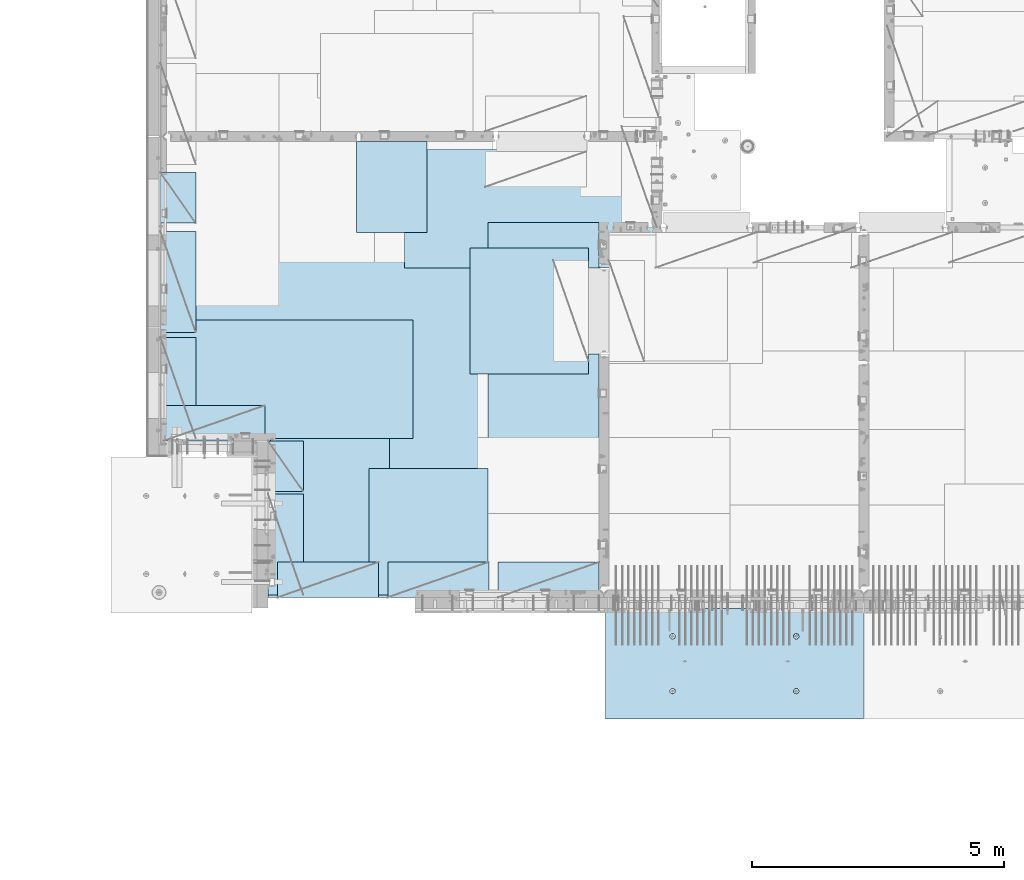
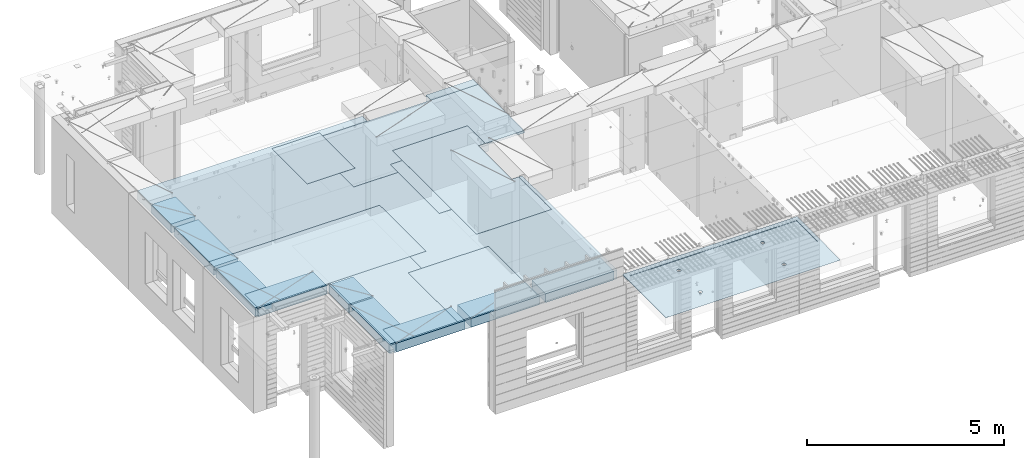
# One storey, part 172 of 309: 16 plates, 2 slabs, 16 elements without a shape of their own.
"""IFC2X3 building model written with IfcOpenShell, lengths in millimetres."""

from ifc_helpers import new_model, si_unit, frame, origin_with_axes, place, context, subcontext, project, spatial, faceted_brep, material, type_object, element, aggregate, save


model = new_model("IFC2X3")

# Units and contexts
model_context = context("Model", 3, precision=1e-05, world=origin_with_axes())
body_context = subcontext(model_context, "Body", "Model", "MODEL_VIEW")
ifc_project = project(units=[si_unit("LENGTHUNIT", "METRE", prefix="MILLI"), si_unit("AREAUNIT", "SQUARE_METRE"), si_unit("VOLUMEUNIT", "CUBIC_METRE"), si_unit("MASSUNIT", "GRAM", prefix="KILO"), si_unit("TIMEUNIT", "SECOND"), si_unit("PLANEANGLEUNIT", "RADIAN"), si_unit("SOLIDANGLEUNIT", "STERADIAN"), si_unit("THERMODYNAMICTEMPERATUREUNIT", "DEGREE_CELSIUS"), si_unit("LUMINOUSINTENSITYUNIT", "LUMEN")], contexts=[model_context])

# Site, building, storey
site_placement = place(None, origin_with_axes())
site = spatial("IfcSite", under=ifc_project, at=site_placement, CompositionType="ELEMENT")
building_placement = place(site_placement, origin_with_axes())
building = spatial("IfcBuilding", under=site, at=building_placement, CompositionType="ELEMENT")
storey_placement = place(building_placement, origin_with_axes())
storey = spatial("IfcBuildingStorey", under=building, at=storey_placement, Name="7", CompositionType="ELEMENT", Elevation=0.0)

# Assembly, slab
assembly_1_placement = place(storey_placement, origin_with_axes())
assembly_1 = element("IfcElementAssembly", 1, at=assembly_1_placement, inside=storey, AssemblyPlace="NOTDEFINED", PredefinedType="REINFORCEMENT_UNIT")
ifc_material_1 = material(Name="CONCRETE/C35/45")
slab_type_1 = type_object("IfcSlabType", PredefinedType="NOTDEFINED")
slab_1_placement = place(assembly_1_placement, frame((21799.9998568133, 7629.99655735226, 102715.0), z_axis=(-1.11800000013248e-06, -0.999999999999375, 0.0), x_axis=(-0.999999999999093, 1.34699999998405e-06, 0.0)))
slab_1 = element("IfcSlab", 2, at=slab_1_placement, type_object=slab_type_1, material=ifc_material_1, PredefinedType="FLOOR", context=body_context, shape_type="Brep", body=[
    faceted_brep([(1280.18660296697, -0.909710330801317, 566.185914834692), (1281.90603936524, 15.0, 565.627238643067), (1289.08870074667, 15.0, 579.724052269637), (1287.6392435987, -0.766307145458995, 580.77714154713), (1300.27597263497, 15.0, 590.911354296481), (1299.23047672458, -0.652565147232963, 592.350351889299), (1314.37276691139, 15.0, 598.0940536547), (1313.8256792785, -0.579567785971449, 599.777808538672), (1329.99919113403, 15.0, 600.569057686296), (1329.99918875315, -0.55441981376498, 602.336605392405), (1345.62562202428, 15.0, 598.094095752294), (1346.17270510536, -0.57956733671017, 599.77785206156), (1359.72243565085, 15.0, 590.911434370867), (1360.76792762748, -0.652564292380703, 592.350434701655), (1370.9097376777, 15.0, 579.724162482574), (1372.35919188042, -0.766305968267261, 580.77725558627), (1378.09243703591, 15.0, 565.627368206145), (1379.81187177946, -0.909708946070168, 566.186048981303), (1380.56744106751, 15.0, 550.000943983501), (1382.39343843141, -1.06877680234902, 550.00094644312), (1378.09247913351, 15.0, 534.374513093253), (1379.84630966614, -1.22795456201129, 533.804661621162), (1370.90981775208, 15.0, 520.277699466684), (1372.41492595986, -1.37164529091388, 519.184177442045), (1359.72254586379, 15.0, 509.09039743984), (1360.82369295531, -1.485742713543, 507.574802784429), (1345.62575158736, 15.0, 501.907698081623), (1346.20723365079, -1.55902761995094, 500.118088510166), (1329.99932736472, 15.0, 499.432694050024), (1329.99932990324, -1.5842854254297, 497.548116160773), (1314.37289647447, 15.0, 501.907655984027), (1313.7914192164, -1.55902807114762, 500.118044797301), (1300.2760828479, 15.0, 509.090317365454), (1299.17493978209, -1.48574357148027, 507.574719664685), (1289.08878082105, 15.0, 520.277589253747), (1287.58367545073, -1.37164647120517, 519.184063095515), (1281.90608146284, 15.0, 534.374383530176), (1280.15225231554, -1.22795594864874, 533.804527284575), (1279.43107743124, 15.0, 550.000807752819), (1277.60507990177, -1.06877825934498, 550.000805293201), (5009.99979799347, -4.99999995394319, 149.999864183354), (99.9997979937543, -4.99999013317574, 150.001528673352), (99.9997979764994, -13.6269858322921, 150.001528664759), (5009.99979797622, -13.6270008655847, 149.99986417476), (100.000487896599, 15.0, 2184.99365234375), (100.000487876598, 5.00000921862375, 2184.99365234375), (5110.00048828125, 15.0, 2184.99365234375), (5010.00048789632, 15.0, 2184.99365234375), (5010.00048787632, 4.99999939870031, 2184.99365234375), (5110.00048828125, 4.99999919869879, 2184.99365234375), (5110.0, 15.0, -1.47338141687214e-10), (5110.0, -15.0, -1.47338141687214e-10), (0.0, 15.0, 0.0), (2.51020537689328e-10, -14.9999911366176, 0.00113955305187119), (0.000232657715969253, 15.0, 2184.99365234375), (0.000232657715969253, 5.00000941862527, 2184.99365234375), (3730.22251860999, 9.43573209954775, 1618.83113331269), (3730.82387439738, 15.0, 1619.026526548), (3728.29325229765, 15.0, 1635.00410637115), (3727.6790114725, 9.59468073869357, 1635.00410554377), (3737.64324823311, 9.2922483417351, 1604.23170736994), (3738.16798272994, 15.0, 1604.61295037772), (3749.2178332121, 9.17831542248314, 1592.63906930656), (3749.60668480233, 15.0, 1593.17427912115), (3763.813280134, 9.10513637620898, 1585.19312428745), (3764.02028075758, 15.0, 1585.83020961879), (3779.99786830435, 9.07991536622285, 1582.62689367248), (3779.99786739818, 15.0, 1583.29963056268), (3796.18244954539, 9.10513682675082, 1585.19316793742), (3795.97544722132, 15.0, 1585.8302526624), (3810.77787636647, 9.17831627919804, 1592.6391523067), (3810.38902339161, 15.0, 1593.17436099496), (3822.35243006372, 9.29224952030927, 1604.23182155193), (3821.82769464817, 15.0, 1604.61306306735), (3829.77312031467, 9.43573348419159, 1618.83126745597), (3829.17176415053, 15.0, 1619.02665902261), (3832.31658386647, 9.59468219359405, 1635.00424649058), (3831.70234320665, 15.0, 1635.0042456632), (3829.73873198269, 9.75352115777787, 1651.16605933226), (3829.17172110693, 15.0, 1650.98182548635), (3822.29677618333, 9.8967177845916, 1665.73626979138), (3821.82761277437, 15.0, 1665.39540165663), (3810.72219128265, 10.0102957908966, 1677.29279557827), (3810.38891070198, 15.0, 1676.8340729132), (3796.14797068512, 10.0831877069577, 1684.70952519025), (3795.97531474672, 15.0, 1684.17814241556), (3779.99772735736, 10.1082990436407, 1687.26459658035), (3779.99772810613, 15.0, 1686.70872147167), (3763.84749089728, 10.0831872583221, 1684.70948172999), (3764.02014828298, 15.0, 1684.17809937195), (3749.27329023921, 10.0102949372667, 1677.29271288508), (3749.6065721127, 15.0, 1676.83399103939), (3737.6987364208, 9.89671660910244, 1665.73615591634), (3738.16790085613, 15.0, 1665.395288967), (3730.25681983225, 9.75351977504033, 1651.16592537868), (3730.82383135377, 15.0, 1650.98169301174), (1280.22251492937, 9.43569802264392, 1618.82783196606), (1280.8238743996, 15.0, 1619.023226398), (1278.29325229988, 15.0, 1635.00080622115), (1277.67900760369, 9.59464667354769, 1635.00080539377), (1287.64324510154, 9.29221425422293, 1604.2284049431), (1288.16798273216, 15.0, 1604.60965022772), (1299.21783093693, 9.17828132653085, 1592.63576602199), (1299.60668480455, 15.0, 1593.17097897115), (1313.81327893874, 9.10510227482882, 1585.18982045196), (1314.02028075981, 15.0, 1585.82690946879), (1329.99786830658, 9.07988126298005, 1582.62358964711), (1329.9978674004, 15.0, 1583.29633041268), (1346.18245074511, 9.10510272538522, 1585.18986410193), (1345.97544722355, 15.0, 1585.8269525124), (1360.77787864609, 9.1782821832312, 1592.63584902213), (1360.38902339383, 15.0, 1593.17106084496), (1372.35243319974, 9.29221543279709, 1604.2285191251), (1371.8276946504, 15.0, 1604.60976291735), (1379.77312399974, 9.43569940728776, 1618.82796610935), (1379.17176415276, 15.0, 1619.02335887261), (1382.31658773973, 9.59464812844817, 1635.00094634059), (1381.70234320888, 15.0, 1635.0009455132), (1379.73873566521, 9.75348710437538, 1651.16276037807), (1379.17172110915, 15.0, 1650.97852533635), (1372.29677931523, 9.89668374179746, 1665.73297191523), (1371.82761277659, 15.0, 1665.39210150663), (1360.72219355815, 10.0102617564989, 1677.28949855719), (1360.3889107042, 15.0, 1676.8307727632), (1346.14797188228, 10.0831536779588, 1684.70622871793), (1345.97531474894, 15.0, 1684.17484226556), (1329.99772735958, 10.1082650164899, 1687.26130029707), (1329.99772810835, 15.0, 1686.70542132167), (1313.84748970455, 10.0831532293232, 1684.70618525766), (1314.0201482852, 15.0, 1684.17479922195), (1299.27328796815, 10.010260902869, 1677.28941586399), (1299.60657211492, 15.0, 1676.83069088939), (1287.69873329334, 9.89668256629375, 1665.73285804018), (1288.16790085835, 15.0, 1665.391988817), (1280.25681615416, 9.7534857216524, 1651.16262642448), (1280.82383135599, 15.0, 1650.97839286174), (3809.72243564863, 15.0, 590.914734520867), (3810.76792535197, -0.652530257968465, 592.353731722741), (3796.17270390819, -0.579533307682141, 599.781148533887), (3795.62562202206, 15.0, 598.097395902295), (3820.90973767548, 15.0, 579.727462632573), (3822.35918874851, -0.76627192547312, 580.780553462419), (3828.09243703369, 15.0, 565.630668356144), (3829.81186809693, -0.909674892682233, 566.189347935494), (3830.56744106529, 15.0, 550.004244133502), (3832.39343455815, -1.06874273720314, 550.004246593115), (3828.09247913129, 15.0, 534.377813243253), (3829.84630598107, -1.22792048507836, 533.807962967788), (3820.90981774986, 15.0, 520.280999616684), (3822.41492282383, -1.3716112034017, 519.187479868876), (3809.72254586156, 15.0, 509.093697589839), (3810.82369067569, -1.48570861757617, 507.578106068997), (3795.62575158514, 15.0, 501.910998231622), (3796.20723245107, -1.55899351858534, 500.121392345655), (3779.99932736249, 15.0, 499.435994200024), (3779.99932990101, -1.58425132217235, 497.551420186142), (3764.37289647224, 15.0, 501.910956134026), (3763.79142041166, -1.55899396976747, 500.121348632794), (3750.27608284568, 15.0, 509.093617515454), (3749.17494205726, -1.48570947552798, 507.578022949257), (3739.08878081883, 15.0, 520.280889403746), (3737.58367858229, -1.37161238366389, 519.187365522354), (3731.90608146061, 15.0, 534.377683680175), (3730.15225599616, -1.22792187171581, 533.807828631209), (3737.63924672617, -0.766273102650302, 580.780439423285), (3749.23047899565, -0.652531112835277, 592.353648910393), (3763.82568047123, -0.579533756972523, 599.781105011002), (3779.99918875093, -0.5543857866287, 602.339901675684), (3727.60508377059, -1.0687441941991, 550.004105443206), (3730.18660664506, -0.90967627739883, 566.189213788893), (3779.99919113181, 15.0, 600.572357836296), (3764.37276690917, 15.0, 598.097353804698), (3750.27597263274, 15.0, 590.914654446481), (3739.08870074445, 15.0, 579.727352419636), (3731.90603936302, 15.0, 565.630538793067), (3729.43107742902, 15.0, 550.00410790282)], [[[0, 1, 2, 3]], [[3, 2, 4, 5]], [[5, 4, 6, 7]], [[7, 6, 8, 9]], [[10, 11, 9, 8]], [[12, 13, 11, 10]], [[14, 15, 13, 12]], [[16, 17, 15, 14]], [[18, 19, 17, 16]], [[20, 21, 19, 18]], [[22, 23, 21, 20]], [[24, 25, 23, 22]], [[26, 27, 25, 24]], [[27, 26, 28, 29]], [[29, 28, 30, 31]], [[31, 30, 32, 33]], [[33, 32, 34, 35]], [[35, 34, 36, 37]], [[37, 36, 38, 39]], [[39, 38, 1, 0]], [[40, 41, 42, 43]], [[41, 44, 45, 42]], [[46, 47, 48, 49]], [[50, 46, 49, 51]], [[52, 50, 51, 53]], [[54, 52, 53, 55]], [[44, 54, 55, 45]], [[53, 51, 49, 48, 43, 42, 45, 55]], [[47, 40, 43, 48]], [[56, 57, 58, 59]], [[60, 61, 57, 56]], [[62, 63, 61, 60]], [[64, 65, 63, 62]], [[66, 67, 65, 64]], [[68, 69, 67, 66]], [[70, 71, 69, 68]], [[71, 70, 72, 73]], [[73, 72, 74, 75]], [[75, 74, 76, 77]], [[77, 76, 78, 79]], [[79, 78, 80, 81]], [[81, 80, 82, 83]], [[83, 82, 84, 85]], [[85, 84, 86, 87]], [[87, 86, 88, 89]], [[90, 91, 89, 88]], [[92, 93, 91, 90]], [[94, 95, 93, 92]], [[59, 58, 95, 94]], [[96, 97, 98, 99]], [[100, 101, 97, 96]], [[102, 103, 101, 100]], [[104, 105, 103, 102]], [[106, 107, 105, 104]], [[108, 109, 107, 106]], [[110, 111, 109, 108]], [[111, 110, 112, 113]], [[113, 112, 114, 115]], [[115, 114, 116, 117]], [[117, 116, 118, 119]], [[119, 118, 120, 121]], [[121, 120, 122, 123]], [[123, 122, 124, 125]], [[125, 124, 126, 127]], [[127, 126, 128, 129]], [[130, 131, 129, 128]], [[132, 133, 131, 130]], [[134, 135, 133, 132]], [[99, 98, 135, 134]], [[136, 137, 138, 139]], [[140, 141, 137, 136]], [[142, 143, 141, 140]], [[144, 145, 143, 142]], [[146, 147, 145, 144]], [[148, 149, 147, 146]], [[150, 151, 149, 148]], [[152, 153, 151, 150]], [[153, 152, 154, 155]], [[155, 154, 156, 157]], [[157, 156, 158, 159]], [[159, 158, 160, 161]], [[161, 160, 162, 163]], [[44, 41, 40, 47], [3, 5, 7, 9, 11, 13, 15, 17, 19, 21, 23, 25, 27, 29, 31, 33, 35, 37, 39, 0], [164, 165, 166, 167, 138, 137, 141, 143, 145, 147, 149, 151, 153, 155, 157, 159, 161, 163, 168, 169], [132, 130, 128, 126, 124, 122, 120, 118, 116, 114, 112, 110, 108, 106, 104, 102, 100, 96, 99, 134], [92, 90, 88, 86, 84, 82, 80, 78, 76, 74, 72, 70, 68, 66, 64, 62, 60, 56, 59, 94]], [[139, 138, 167, 170]], [[166, 171, 170, 167]], [[165, 172, 171, 166]], [[164, 173, 172, 165]], [[169, 174, 173, 164]], [[168, 175, 174, 169]], [[163, 162, 175, 168]], [[46, 50, 52, 54, 44, 47], [34, 32, 30, 28, 26, 24, 22, 20, 18, 16, 14, 12, 10, 8, 6, 4, 2, 1, 38, 36], [160, 158, 156, 154, 152, 150, 148, 146, 144, 142, 140, 136, 139, 170, 171, 172, 173, 174, 175, 162], [101, 103, 105, 107, 109, 111, 113, 115, 117, 119, 121, 123, 125, 127, 129, 131, 133, 135, 98, 97], [61, 63, 65, 67, 69, 71, 73, 75, 77, 79, 81, 83, 85, 87, 89, 91, 93, 95, 58, 57]]]),
])
aggregate(assembly_1, [slab_1])

# Assembly, plate
assembly_2_placement = place(storey_placement, origin_with_axes())
assembly_2 = element("IfcElementAssembly", 3, at=assembly_2_placement, inside=storey, Name="Steel Assembly", AssemblyPlace="NOTDEFINED", PredefinedType="NOTDEFINED")
ifc_material_2 = material()
plate_type_1 = type_object("IfcPlateType", PredefinedType="NOTDEFINED")
plate_1_placement = place(assembly_2_placement, frame((14009.7695320312, 12275.0000289158, 102695.1), z_axis=(0.0, 1.0, 0.0), x_axis=(1.0, 0.0, 0.0)))
plate_1 = element("IfcPlate", 4, at=plate_1_placement, type_object=plate_type_1, material=ifc_material_2, Name="1/2", context=body_context, shape_type="Brep", body=[
    faceted_brep([(0.0, -35.0, 0.0), (0.0, -35.0, 2500.0), (0.0, 35.0, 2500.0), (0.0, 35.0, 0.0), (2349.99951171875, -35.0, 2500.0), (2349.99951171875, 35.0, 2500.0), (2350.0, -35.0, 0.0), (2350.0, 35.0, 0.0)], [[[0, 1, 2, 3]], [[1, 4, 5, 2]], [[4, 6, 7, 5]], [[6, 0, 3, 7]], [[5, 7, 3, 2]], [[6, 4, 1, 0]]]),
])
aggregate(assembly_2, [plate_1])

assembly_3_placement = place(storey_placement, origin_with_axes())
assembly_3 = element("IfcElementAssembly", 5, at=assembly_3_placement, inside=storey, Name="Steel Assembly", AssemblyPlace="NOTDEFINED", PredefinedType="NOTDEFINED")
plate_2_placement = place(assembly_3_placement, frame((14360.0, 10400.0, 102695.1), z_axis=(0.0, -1.0, 0.0), x_axis=(-1.0, 3.00000001838171e-08, 0.0)))
plate_2 = element("IfcPlate", 6, at=plate_2_placement, type_object=plate_type_1, material=ifc_material_2, Name="1/2", context=body_context, shape_type="Brep", body=[
    faceted_brep([(0.0, -35.0, 0.0), (0.0, -35.0, 2500.0), (0.0, 35.0, 2500.0), (0.0, 35.0, 0.0), (2349.99951171875, -35.0, 2500.0), (2349.99951171875, 35.0, 2500.0), (2350.0, -35.0, 0.0), (2350.0, 35.0, 0.0)], [[[0, 1, 2, 3]], [[1, 4, 5, 2]], [[4, 6, 7, 5]], [[6, 0, 3, 7]], [[5, 7, 3, 2]], [[6, 4, 1, 0]]]),
])
aggregate(assembly_3, [plate_2])

assembly_4_placement = place(storey_placement, origin_with_axes())
assembly_4 = element("IfcElementAssembly", 7, at=assembly_4_placement, inside=storey, Name="Steel Assembly", AssemblyPlace="NOTDEFINED", PredefinedType="NOTDEFINED")
plate_3_placement = place(assembly_4_placement, frame((12710.0, 16725.0, 102695.1), z_axis=(1.0, 0.0, 0.0), x_axis=(0.0, -1.0, 0.0)))
plate_3 = element("IfcPlate", 8, at=plate_3_placement, type_object=plate_type_1, material=ifc_material_2, context=body_context, shape_type="Brep", body=[
    faceted_brep([(0.0, -35.0, 0.0), (0.0, -35.0, 5000.0), (0.0, 35.0, 5000.0), (0.0, 35.0, 0.0), (2349.99951171875, -35.0, 5000.0), (2349.99951171875, 35.0, 5000.0), (2350.0, -35.0, 0.0), (2350.0, 35.0, 0.0)], [[[0, 1, 2, 3]], [[1, 4, 5, 2]], [[4, 6, 7, 5]], [[6, 0, 3, 7]], [[5, 7, 3, 2]], [[6, 4, 1, 0]]]),
])
aggregate(assembly_4, [plate_3])

assembly_5_placement = place(storey_placement, origin_with_axes())
assembly_5 = element("IfcElementAssembly", 9, at=assembly_5_placement, inside=storey, Name="Steel Assembly", AssemblyPlace="NOTDEFINED", PredefinedType="NOTDEFINED")
plate_4_placement = place(assembly_5_placement, frame((10060.0, 7900.0, 102695.1), z_axis=(0.0, 1.0, 0.0), x_axis=(1.0, 0.0, 0.0)))
plate_4 = element("IfcPlate", 10, at=plate_4_placement, type_object=plate_type_1, material=ifc_material_2, context=body_context, shape_type="Brep", body=[
    faceted_brep([(0.0, -35.0, 0.0), (0.0, -35.0, 5000.0), (0.0, 35.0, 5000.0), (0.0, 35.0, 0.0), (2349.99951171875, -35.0, 5000.0), (2349.99951171875, 35.0, 5000.0), (2350.0, -35.0, 0.0), (2350.0, 35.0, 0.0)], [[[0, 1, 2, 3]], [[1, 4, 5, 2]], [[4, 6, 7, 5]], [[6, 0, 3, 7]], [[5, 7, 3, 2]], [[6, 4, 1, 0]]]),
])
aggregate(assembly_5, [plate_4])

assembly_6_placement = place(storey_placement, origin_with_axes())
assembly_6 = element("IfcElementAssembly", 11, at=assembly_6_placement, inside=storey, Name="Steel Assembly", AssemblyPlace="NOTDEFINED", PredefinedType="NOTDEFINED")
plate_5_placement = place(assembly_6_placement, frame((12880.0, 11000.0, 102695.1), z_axis=(-1.0, 3.00000001838171e-08, 0.0), x_axis=(0.0, 1.0, 0.0)))
plate_5 = element("IfcPlate", 12, at=plate_5_placement, type_object=plate_type_1, material=ifc_material_2, context=body_context, shape_type="Brep", body=[
    faceted_brep([(0.0, -35.0, 0.0), (0.0, -35.0, 5000.0), (0.0, 35.0, 5000.0), (0.0, 35.0, 0.0), (2349.99951171875, -35.0, 5000.0), (2349.99951171875, 35.0, 5000.0), (2350.0, -35.0, 0.0), (2350.0, 35.0, 0.0)], [[[0, 1, 2, 3]], [[1, 4, 5, 2]], [[4, 6, 7, 5]], [[6, 0, 3, 7]], [[5, 7, 3, 2]], [[6, 4, 1, 0]]]),
])
aggregate(assembly_6, [plate_5])

assembly_7_placement = place(storey_placement, origin_with_axes())
assembly_7 = element("IfcElementAssembly", 13, at=assembly_7_placement, inside=storey, Name="Steel Assembly", AssemblyPlace="NOTDEFINED", PredefinedType="NOTDEFINED")
plate_type_2 = type_object("IfcPlateType", PredefinedType="NOTDEFINED")
plate_6_placement = place(assembly_7_placement, frame((7879.99987792969, 13000.0, 102595.3), z_axis=(1.0, 0.0, 0.0), x_axis=(0.0, -1.0, 0.0)))
plate_6 = element("IfcPlate", 14, at=plate_6_placement, type_object=plate_type_2, material=ifc_material_2, Name="RE1", context=body_context, shape_type="Brep", body=[
    faceted_brep([(1.81898940354586e-12, -135.0, 1.81898940354586e-12), (0.0, -135.0, 699.999999999996), (0.0, 135.0, 699.999999999996), (1.81898940354586e-12, 135.0, 1.81898940354586e-12), (1999.99951171875, -135.0, 699.999999999993), (1999.99951171875, 135.0, 699.999999999993), (2000.0, -135.0, -3.63797880709171e-12), (2000.0, 135.0, -3.63797880709171e-12)], [[[0, 1, 2, 3]], [[1, 4, 5, 2]], [[4, 6, 7, 5]], [[6, 0, 3, 7]], [[5, 7, 3, 2]], [[6, 4, 1, 0]]]),
])
aggregate(assembly_7, [plate_6])

assembly_8_placement = place(storey_placement, origin_with_axes())
assembly_8 = element("IfcElementAssembly", 15, at=assembly_8_placement, inside=storey, Name="Steel Assembly", AssemblyPlace="NOTDEFINED", PredefinedType="NOTDEFINED")
plate_7_placement = place(assembly_8_placement, frame((7945.00085423865, 10950.0001036336, 102595.3), z_axis=(0.0, 1.0, 0.0), x_axis=(1.0, 0.0, 0.0)))
plate_7 = element("IfcPlate", 16, at=plate_7_placement, type_object=plate_type_2, material=ifc_material_2, Name="RE1", context=body_context, shape_type="Brep", body=[
    faceted_brep([(1.81898940354586e-12, -135.0, 1.81898940354586e-12), (0.0, -135.0, 699.999999999996), (0.0, 135.0, 699.999999999996), (1.81898940354586e-12, 135.0, 1.81898940354586e-12), (1999.99951171875, -135.0, 699.999999999993), (1999.99951171875, 135.0, 699.999999999993), (2000.0, -135.0, -3.63797880709171e-12), (2000.0, 135.0, -3.63797880709171e-12)], [[[0, 1, 2, 3]], [[1, 4, 5, 2]], [[4, 6, 7, 5]], [[6, 0, 3, 7]], [[5, 7, 3, 2]], [[6, 4, 1, 0]]]),
])
aggregate(assembly_8, [plate_7])

assembly_9_placement = place(storey_placement, origin_with_axes())
assembly_9 = element("IfcElementAssembly", 17, at=assembly_9_placement, inside=storey, Name="Steel Assembly", AssemblyPlace="NOTDEFINED", PredefinedType="NOTDEFINED")
plate_8_placement = place(assembly_9_placement, frame((10009.9998779297, 9900.0, 102595.3), z_axis=(1.0, 0.0, 0.0), x_axis=(0.0, -1.0, 0.0)))
plate_8 = element("IfcPlate", 18, at=plate_8_placement, type_object=plate_type_2, material=ifc_material_2, Name="RE1", context=body_context, shape_type="Brep", body=[
    faceted_brep([(1.81898940354586e-12, -135.0, 1.81898940354586e-12), (0.0, -135.0, 699.999999999996), (0.0, 135.0, 699.999999999996), (1.81898940354586e-12, 135.0, 1.81898940354586e-12), (1999.99951171875, -135.0, 699.999999999993), (1999.99951171875, 135.0, 699.999999999993), (2000.0, -135.0, -3.63797880709171e-12), (2000.0, 135.0, -3.63797880709171e-12)], [[[0, 1, 2, 3]], [[1, 4, 5, 2]], [[4, 6, 7, 5]], [[6, 0, 3, 7]], [[5, 7, 3, 2]], [[6, 4, 1, 0]]]),
])
aggregate(assembly_9, [plate_8])

assembly_10_placement = place(storey_placement, origin_with_axes())
assembly_10 = element("IfcElementAssembly", 19, at=assembly_10_placement, inside=storey, Name="Steel Assembly", AssemblyPlace="NOTDEFINED", PredefinedType="NOTDEFINED")
plate_9_placement = place(assembly_10_placement, frame((10009.9999999293, 10950.0, 102595.3), z_axis=(1.0, 0.0, 0.0), x_axis=(0.0, -1.0, 0.0)))
plate_9 = element("IfcPlate", 20, at=plate_9_placement, type_object=plate_type_2, material=ifc_material_2, Name="RE1_1/2", context=body_context, shape_type="Brep", body=[
    faceted_brep([(1.81898940354586e-12, -135.0, 1.81898940354586e-12), (0.0, -135.0, 699.999999999996), (0.0, 135.0, 699.999999999996), (1.81898940354586e-12, 135.0, 1.81898940354586e-12), (999.99951171875, -135.0, 700.0), (999.99951171875, 135.0, 700.0), (1000.0, -135.0, 0.0), (1000.0, 135.0, 0.0)], [[[0, 1, 2, 3]], [[1, 4, 5, 2]], [[4, 6, 7, 5]], [[6, 0, 3, 7]], [[5, 7, 3, 2]], [[6, 4, 1, 0]]]),
])
aggregate(assembly_10, [plate_9])

assembly_11_placement = place(storey_placement, origin_with_axes())
assembly_11 = element("IfcElementAssembly", 21, at=assembly_11_placement, inside=storey, Name="Steel Assembly", AssemblyPlace="NOTDEFINED", PredefinedType="NOTDEFINED")
plate_10_placement = place(assembly_11_placement, frame((7879.99999992931, 16265.0, 102595.3), z_axis=(1.0, 0.0, 0.0), x_axis=(0.0, -1.0, 0.0)))
plate_10 = element("IfcPlate", 22, at=plate_10_placement, type_object=plate_type_2, material=ifc_material_2, Name="RE1_1/2", context=body_context, shape_type="Brep", body=[
    faceted_brep([(1.81898940354586e-12, -135.0, 1.81898940354586e-12), (0.0, -135.0, 699.999999999996), (0.0, 135.0, 699.999999999996), (1.81898940354586e-12, 135.0, 1.81898940354586e-12), (999.99951171875, -135.0, 700.0), (999.99951171875, 135.0, 700.0), (1000.0, -135.0, 0.0), (1000.0, 135.0, 0.0)], [[[0, 1, 2, 3]], [[1, 4, 5, 2]], [[4, 6, 7, 5]], [[6, 0, 3, 7]], [[5, 7, 3, 2]], [[6, 4, 1, 0]]]),
])
aggregate(assembly_11, [plate_10])

assembly_12_placement = place(storey_placement, origin_with_axes())
assembly_12 = element("IfcElementAssembly", 23, at=assembly_12_placement, inside=storey, Name="Steel Assembly", AssemblyPlace="NOTDEFINED", PredefinedType="NOTDEFINED")
plate_11_placement = place(assembly_12_placement, frame((10200.0008542386, 7850.00010363356, 102595.3), z_axis=(0.0, 1.0, 0.0), x_axis=(1.0, 0.0, 0.0)))
plate_11 = element("IfcPlate", 24, at=plate_11_placement, type_object=plate_type_2, material=ifc_material_2, Name="RE1", context=body_context, shape_type="Brep", body=[
    faceted_brep([(1.81898940354586e-12, -135.0, 1.81898940354586e-12), (0.0, -135.0, 699.999999999996), (0.0, 135.0, 699.999999999996), (1.81898940354586e-12, 135.0, 1.81898940354586e-12), (1999.99951171875, -135.0, 699.999999999993), (1999.99951171875, 135.0, 699.999999999993), (2000.0, -135.0, -3.63797880709171e-12), (2000.0, 135.0, -3.63797880709171e-12)], [[[0, 1, 2, 3]], [[1, 4, 5, 2]], [[4, 6, 7, 5]], [[6, 0, 3, 7]], [[5, 7, 3, 2]], [[6, 4, 1, 0]]]),
])
aggregate(assembly_12, [plate_11])

assembly_13_placement = place(storey_placement, origin_with_axes())
assembly_13 = element("IfcElementAssembly", 25, at=assembly_13_placement, inside=storey, Name="Steel Assembly", AssemblyPlace="NOTDEFINED", PredefinedType="NOTDEFINED")
plate_12_placement = place(assembly_13_placement, frame((14565.0008542386, 7850.00010363356, 102595.3), z_axis=(0.0, 1.0, 0.0), x_axis=(1.0, 0.0, 0.0)))
plate_12 = element("IfcPlate", 26, at=plate_12_placement, type_object=plate_type_2, material=ifc_material_2, Name="RE1", context=body_context, shape_type="Brep", body=[
    faceted_brep([(1.81898940354586e-12, -135.0, 1.81898940354586e-12), (0.0, -135.0, 699.999999999996), (0.0, 135.0, 699.999999999996), (1.81898940354586e-12, 135.0, 1.81898940354586e-12), (1999.99951171875, -135.0, 699.999999999993), (1999.99951171875, 135.0, 699.999999999993), (2000.0, -135.0, -3.63797880709171e-12), (2000.0, 135.0, -3.63797880709171e-12)], [[[0, 1, 2, 3]], [[1, 4, 5, 2]], [[4, 6, 7, 5]], [[6, 0, 3, 7]], [[5, 7, 3, 2]], [[6, 4, 1, 0]]]),
])
aggregate(assembly_13, [plate_12])

assembly_14_placement = place(storey_placement, origin_with_axes())
assembly_14 = element("IfcElementAssembly", 27, at=assembly_14_placement, inside=storey, Name="Steel Assembly", AssemblyPlace="NOTDEFINED", PredefinedType="NOTDEFINED")
plate_13_placement = place(assembly_14_placement, frame((12382.5008542386, 7850.00010363356, 102595.3), z_axis=(0.0, 1.0, 0.0), x_axis=(1.0, 0.0, 0.0)))
plate_13 = element("IfcPlate", 28, at=plate_13_placement, type_object=plate_type_2, material=ifc_material_2, Name="RE1", context=body_context, shape_type="Brep", body=[
    faceted_brep([(1.81898940354586e-12, -135.0, 1.81898940354586e-12), (0.0, -135.0, 699.999999999996), (0.0, 135.0, 699.999999999996), (1.81898940354586e-12, 135.0, 1.81898940354586e-12), (1999.99951171875, -135.0, 699.999999999993), (1999.99951171875, 135.0, 699.999999999993), (2000.0, -135.0, -3.63797880709171e-12), (2000.0, 135.0, -3.63797880709171e-12)], [[[0, 1, 2, 3]], [[1, 4, 5, 2]], [[4, 6, 7, 5]], [[6, 0, 3, 7]], [[5, 7, 3, 2]], [[6, 4, 1, 0]]]),
])
aggregate(assembly_14, [plate_13])

assembly_15_placement = place(storey_placement, origin_with_axes())
assembly_15 = element("IfcElementAssembly", 29, at=assembly_15_placement, inside=storey, Name="Steel Assembly", AssemblyPlace="NOTDEFINED", PredefinedType="NOTDEFINED")
plate_14_placement = place(assembly_15_placement, frame((7879.99987792969, 15100.0, 102595.3), z_axis=(1.0, 0.0, 0.0), x_axis=(0.0, -1.0, 0.0)))
plate_14 = element("IfcPlate", 30, at=plate_14_placement, type_object=plate_type_2, material=ifc_material_2, Name="RE1", context=body_context, shape_type="Brep", body=[
    faceted_brep([(1.81898940354586e-12, -135.0, 1.81898940354586e-12), (0.0, -135.0, 699.999999999996), (0.0, 135.0, 699.999999999996), (1.81898940354586e-12, 135.0, 1.81898940354586e-12), (1999.99951171875, -135.0, 699.999999999993), (1999.99951171875, 135.0, 699.999999999993), (2000.0, -135.0, -3.63797880709171e-12), (2000.0, 135.0, -3.63797880709171e-12)], [[[0, 1, 2, 3]], [[1, 4, 5, 2]], [[4, 6, 7, 5]], [[6, 0, 3, 7]], [[5, 7, 3, 2]], [[6, 4, 1, 0]]]),
])
aggregate(assembly_15, [plate_14])

# Assembly, plates, slab
assembly_16_placement = place(storey_placement, origin_with_axes())
assembly_16 = element("IfcElementAssembly", 31, at=assembly_16_placement, inside=storey, AssemblyPlace="NOTDEFINED", PredefinedType="REINFORCEMENT_UNIT")
plate_type_3 = type_object("IfcPlateType", PredefinedType="NOTDEFINED")
plate_15_placement = place(assembly_16_placement, frame((13159.9998642727, 15079.9997757405, 102725.45), z_axis=(-1.0, 3.00000001838171e-08, 0.0), x_axis=(0.0, 1.0, 0.0)))
plate_15 = element("IfcPlate", 32, at=plate_15_placement, type_object=plate_type_3, material=ifc_material_2, context=body_context, shape_type="Brep", body=[
    faceted_brep([(0.0, -5.0, 0.0), (0.0, -5.0, 1399.99963378906), (0.0, 5.0, 1399.99963378906), (0.0, 5.0, 0.0), (1800.00024414063, -5.0, 1399.99963378906), (1800.00024414063, 5.0, 1399.99963378906), (1800.00024414063, -5.0, 0.0), (1800.00024414063, 5.0, 0.0)], [[[0, 1, 2, 3]], [[1, 4, 5, 2]], [[4, 6, 7, 5]], [[6, 0, 3, 7]], [[5, 7, 3, 2]], [[6, 4, 1, 0]]]),
])
plate_type_4 = type_object("IfcPlateType", PredefinedType="NOTDEFINED")
plate_16_placement = place(assembly_16_placement, frame((16559.9994828029, 15279.9995850056, 102725.45), z_axis=(0.0, -1.0, 0.0), x_axis=(-1.0, 3.00000001838171e-08, 0.0)))
plate_16 = element("IfcPlate", 33, at=plate_16_placement, type_object=plate_type_4, material=ifc_material_2, context=body_context, shape_type="Brep", body=[
    faceted_brep([(0.0, -5.0, 2604.99950854713), (0.0, 5.0, 2604.99950854713), (200.234115600586, 5.0, 2604.99950854713), (200.234115600586, -5.0, 2604.99950854713), (200.234115600586, 5.0, 904.999508547127), (200.234115600586, -5.0, 904.999508547127), (0.0, -5.0, 904.999508547127), (0.0, 5.0, 904.999508547127), (0.0, -5.0, 4271.99951171875), (2191.99951171875, -5.0, 4271.99951171875), (2191.99951171875, 5.0, 4271.99951171875), (0.0, 5.0, 4271.99951171875), (2191.99951171875, -5.0, 0.0), (2191.99951171875, 5.0, 0.0), (0.0, -5.0, 0.0), (0.0, 5.0, 0.0)], [[[0, 1, 2, 3]], [[3, 2, 4, 5]], [[6, 5, 4, 7]], [[8, 9, 10, 11]], [[9, 12, 13, 10]], [[12, 14, 15, 13]], [[15, 14, 6, 7]], [[2, 1, 11, 10, 13, 15, 7, 4]], [[8, 11, 1, 0]], [[14, 12, 9, 8, 0, 3, 5, 6]]]),
])
ifc_material_3 = material(Name="CONCRETE/C30/37")
slab_type_2 = type_object("IfcSlabType", PredefinedType="NOTDEFINED")
slab_2_placement = place(assembly_16_placement, frame((10010.0, 7850.0, 102595.0), z_axis=(0.0, 1.0, 0.0), x_axis=(1.0, 0.0, 0.0)))
slab_2 = element("IfcSlab", 34, at=slab_2_placement, type_object=slab_type_2, material=ifc_material_3, PredefinedType="FLOOR", context=body_context, shape_type="Brep", body=[
    faceted_brep([(4453.68914550781, -135.0, 9130.0), (-2130.0, -135.0, 9130.0), (-2130.0, -135.0, 3100.0), (0.0, -135.0, 3100.0), (1.81898940354586e-12, -135.0, 1.81898940354586e-12), (6650.0, -135.0, 0.0), (6650.0, -135.0, 4825.00007645847), (6349.76536720235, -135.0, 4825.00007645847), (6349.76536720235, -135.0, 6525.00007645847), (6649.99998634297, -135.0, 6525.00007645847), (6650.0, -135.0, 7330.0), (7700.0, -135.0, 7330.0), (7700.0, -135.0, 9130.0), (6319.99914550781, -135.0, 9130.0), (6319.99914550781, -135.0, 8830.0), (6153.68914550781, -135.0, 8830.0), (4520.0, -135.0, 8830.0), (4453.69, -135.0, 8830.0), (-2130.0, 135.0, 9130.0), (4453.68914550781, 135.0, 9130.0), (-2130.0, 135.0, 3100.0), (0.0, 135.0, 3100.0), (1.81898940354586e-12, 135.0, 1.81898940354586e-12), (6650.0, 135.0, 0.0), (6650.0, 135.0, 4825.00007645847), (6349.76536720235, 135.0, 4825.00007645847), (6349.76536720235, 135.0, 6525.00007645847), (6650.0, 135.0, 6525.00007645847), (6650.0, 135.0, 7330.0), (7700.0, 135.0, 7330.0), (7700.0, 135.0, 9130.0), (6319.99914550781, 135.0, 9130.0), (6319.99914550781, 135.0, 8830.0), (6153.68914550781, 135.0, 8830.0), (4520.0, 135.0, 8830.0), (4453.69, 135.0, 8830.0)], [[[0, 1, 2, 3, 4, 5, 6, 7, 8, 9, 10, 11, 12, 13, 14, 15, 16, 17]], [[18, 1, 0, 19]], [[2, 1, 18, 20]], [[3, 2, 20, 21]], [[4, 3, 21, 22]], [[5, 4, 22, 23]], [[5, 23, 24, 6]], [[6, 24, 25, 7]], [[7, 25, 26, 8]], [[9, 8, 26, 27]], [[28, 10, 9, 27]], [[11, 10, 28, 29]], [[12, 11, 29, 30]], [[12, 30, 31, 13]], [[13, 31, 32, 14]], [[15, 14, 32, 33, 34, 16]], [[16, 34, 35, 17]], [[33, 32, 31, 30, 29, 28, 27, 26, 25, 24, 23, 22, 21, 20, 18, 19, 35, 34]], [[0, 17, 35, 19]]]),
])
aggregate(assembly_16, [plate_15, plate_16, slab_2])

save(model, "model.ifc")
